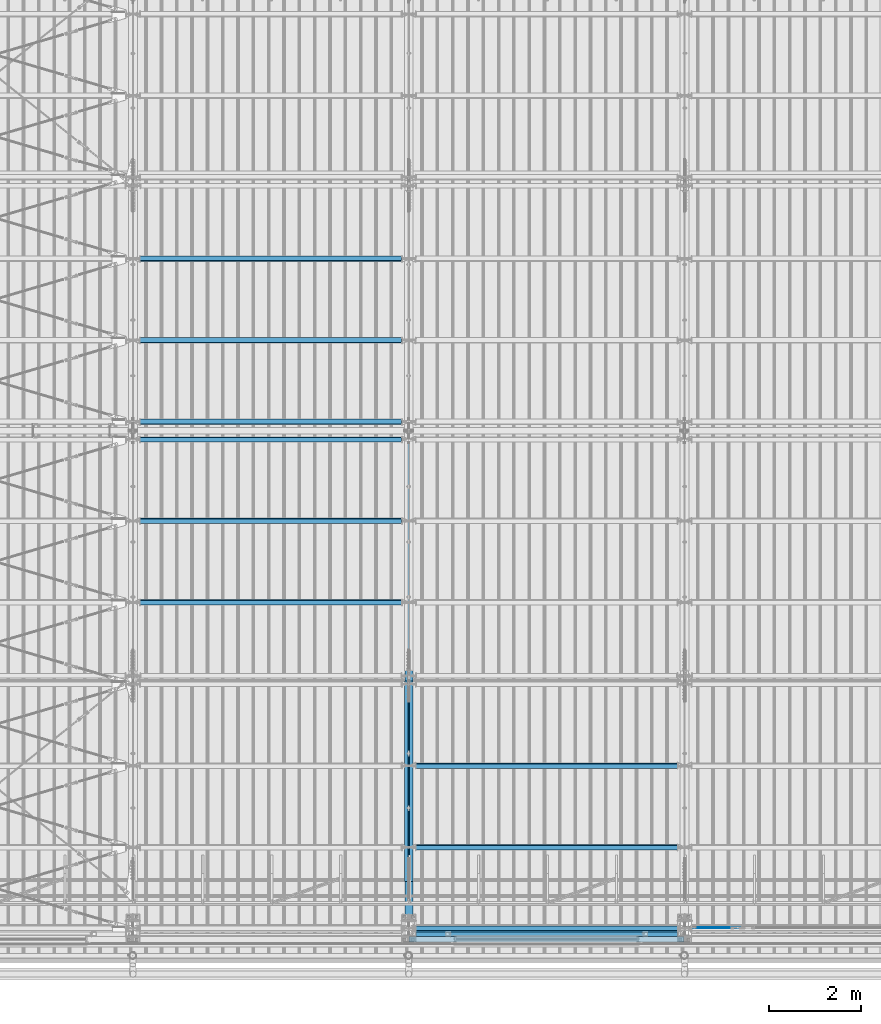
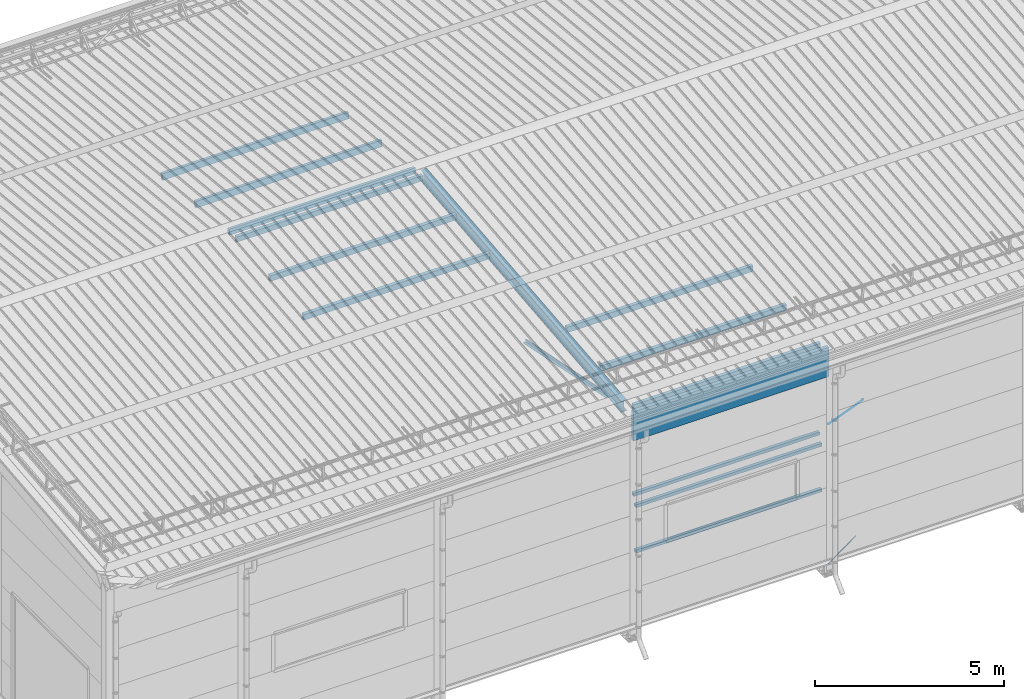
# One storey, part 251 of 709: 16 beams, 2 members, 2 openings, 18 elements without a shape of their own.
"""IFC4 building model written with IfcOpenShell, lengths in millimetres."""

from ifc_helpers import new_model, si_unit, direction, frame, origin_with_axes, place, context, subcontext, project, spatial, line, indexed_curve, outline, extrude, polygons, material, element, aggregate, save


model = new_model("IFC4")

# Units and contexts
model_context = context("Model", 3, precision=0.2, world=origin_with_axes(), true_north=direction((0.0, 1.0)))
body_context = subcontext(model_context, "Body", "Model", "MODEL_VIEW")
reference_context = subcontext(model_context, "Reference", "Model", "MODEL_VIEW")
ifc_project = project(units=[si_unit("LENGTHUNIT", "METRE", prefix="MILLI"), si_unit("AREAUNIT", "SQUARE_METRE"), si_unit("VOLUMEUNIT", "CUBIC_METRE"), si_unit("MASSUNIT", "GRAM", prefix="KILO"), si_unit("TIMEUNIT", "SECOND"), si_unit("PLANEANGLEUNIT", "RADIAN"), si_unit("SOLIDANGLEUNIT", "STERADIAN"), si_unit("THERMODYNAMICTEMPERATUREUNIT", "DEGREE_CELSIUS"), si_unit("LUMINOUSINTENSITYUNIT", "LUMEN")], contexts=[model_context])

# Site, building, storey
site_placement = place(None, origin_with_axes())
site = spatial("IfcSite", under=ifc_project, at=site_placement, CompositionType="ELEMENT")
building_placement = place(site_placement, origin_with_axes())
building = spatial("IfcBuilding", under=site, at=building_placement, Name="Undefined", CompositionType="ELEMENT")
storey_placement = place(building_placement, origin_with_axes())
storey = spatial("IfcBuildingStorey", under=building, at=storey_placement, Name="Undefined", CompositionType="ELEMENT", Elevation=0.0)

# Assembly, beam
assembly_1_placement = place(storey_placement, frame((16000.0, 346.0, 7089.70002), z_axis=(1.0, 0.0, 0.0), x_axis=(0.0, 0.9950371902, 0.099503719)))
assembly_1 = element("IfcElementAssembly", 1, at=assembly_1_placement, inside=storey)
ifc_material_1 = material(Name="C355-5", Category="STEEL")
beam_1_placement = place(assembly_1_placement, origin_with_axes())
beam_1 = element("IfcBeam", 2, at=beam_1_placement, material=ifc_material_1, ObjectType="432", context=body_context, shape_type="Tessellation", body=[
    polygons([(3.80474, -173.0, -87.0), (4.70474, -164.0, -87.0), (10665.6128, -164.0, -87.0), (10664.7128, -173.0, -87.0), (4.70474, -164.0, -3.0), (10665.6128, -164.0, -3.0), (37.50474, 164.0, -3.0), (10698.4128, 164.0, -3.0), (37.50474, 164.0, -87.0), (10698.4128, 164.0, -87.0), (38.40474, 173.0, -87.0), (10699.3128, 173.0, -87.0), (38.40474, 173.0, 87.0), (10699.3128, 173.0, 87.0), (37.50474, 164.0, 87.0), (10698.4128, 164.0, 87.0), (37.50474, 164.0, 3.0), (10698.4128, 164.0, 3.0), (4.70474, -164.0, 3.0), (10665.6128, -164.0, 3.0), (4.70474, -164.0, 87.0), (10665.6128, -164.0, 87.0), (3.80474, -173.0, 87.0), (10664.7128, -173.0, 87.0)], [[[1, 2, 3, 4]], [[2, 5, 6, 3]], [[5, 7, 8, 6]], [[7, 9, 10, 8]], [[9, 11, 12, 10]], [[11, 13, 14, 12]], [[13, 15, 16, 14]], [[15, 17, 18, 16]], [[17, 19, 20, 18]], [[19, 21, 22, 20]], [[21, 23, 24, 22]], [[23, 1, 4, 24]], [[6, 8, 10, 12, 14, 16, 18, 20, 22, 24, 4, 3]], [[23, 21, 19, 17, 15, 13, 11, 9, 7, 5, 2, 1]]], closed=True),
])
aggregate(assembly_1, [beam_1])

assembly_2_placement = place(storey_placement, frame((15949.0, 350.0596, 7109.99804), z_axis=(0.0, 0.1961161349, 0.9805806757), x_axis=(0.0, 0.9805806757, -0.1961161349)))
assembly_2 = element("IfcElementAssembly", 3, at=assembly_2_placement, inside=storey)
ifc_material_2 = material(Name="C345-5", Category="STEEL")
beam_2_placement = place(assembly_2_placement, origin_with_axes())
beam_2 = element("IfcBeam", 4, at=beam_2_placement, material=ifc_material_2, ObjectType="444", context=body_context, shape_type="Tessellation", body=[
    polygons([(868.11437, -45.0, -45.0), (868.11437, 45.0, -45.0), (5317.375, 45.0, -45.0), (5317.375, -45.0, -45.0), (868.11437, 45.0, -39.0), (5317.375, 45.0, -39.0), (868.11437, -39.0, -39.0), (5317.375, -39.0, -39.0), (868.11437, -39.0, 45.0), (5317.375, -39.0, 45.0), (868.11437, -45.0, 45.0), (5317.375, -45.0, 45.0)], [[[1, 2, 3, 4]], [[2, 5, 6, 3]], [[5, 7, 8, 6]], [[7, 9, 10, 8]], [[9, 11, 12, 10]], [[11, 1, 4, 12]], [[6, 8, 10, 12, 4, 3]], [[11, 9, 7, 5, 2, 1]]], closed=True),
])
aggregate(assembly_2, [beam_2])

assembly_3_placement = place(storey_placement, frame((16051.0, 5677.0596, 6044.59804), z_axis=(0.0, 0.1961161349, 0.9805806757), x_axis=(0.0, -0.9805806757, 0.1961161349)))
assembly_3 = element("IfcElementAssembly", 5, at=assembly_3_placement, inside=storey)
beam_3_placement = place(assembly_3_placement, origin_with_axes())
beam_3 = element("IfcBeam", 6, at=beam_3_placement, material=ifc_material_2, ObjectType="444", context=body_context, shape_type="Tessellation", body=[
    polygons([(115.12039, -45.0, -45.0), (115.12039, 45.0, -45.0), (4564.38102, 45.0, -45.0), (4564.38102, -45.0, -45.0), (115.12039, 45.0, -39.0), (4564.38102, 45.0, -39.0), (115.12039, -39.0, -39.0), (4564.38102, -39.0, -39.0), (115.12039, -39.0, 45.0), (4564.38102, -39.0, 45.0), (115.12039, -45.0, 45.0), (4564.38102, -45.0, 45.0)], [[[1, 2, 3, 4]], [[2, 5, 6, 3]], [[5, 7, 8, 6]], [[7, 9, 10, 8]], [[9, 11, 12, 10]], [[11, 1, 4, 12]], [[6, 8, 10, 12, 4, 3]], [[11, 9, 7, 5, 2, 1]]], closed=True),
])
aggregate(assembly_3, [beam_3])

assembly_4_placement = place(storey_placement, frame((16000.0, 50.0, 2550.0), z_axis=(0.0, 0.0, -1.0), x_axis=(1.0, 0.0, 0.0)))
assembly_4 = element("IfcElementAssembly", 7, at=assembly_4_placement, inside=storey)
ifc_material_3 = material(Name="C355", Category="STEEL")
beam_4_placement = place(assembly_4_placement, origin_with_axes())
beam_4 = element("IfcBeam", 8, at=beam_4_placement, material=ifc_material_3, ObjectType="545", context=body_context, shape_type="Tessellation", body=[
    polygons([(155.0, -47.0, -47.0), (155.0, -47.0, 47.0), (5845.0, -47.0, 47.0), (5845.0, -47.0, -47.0), (155.0, 47.0, 47.0), (5845.0, 47.0, 47.0), (155.0, 47.0, -47.0), (5845.0, 47.0, -47.0), (155.0, -50.0, -50.0), (155.0, 50.0, -50.0), (5845.0, 50.0, -50.0), (5845.0, -50.0, -50.0), (155.0, 50.0, 50.0), (5845.0, 50.0, 50.0), (155.0, -50.0, 50.0), (5845.0, -50.0, 50.0)], [[[1, 2, 3, 4]], [[2, 5, 6, 3]], [[5, 7, 8, 6]], [[7, 1, 4, 8]], [[9, 10, 11, 12]], [[10, 13, 14, 11]], [[13, 15, 16, 14]], [[15, 9, 12, 16]], [[14, 16, 12, 11], [6, 8, 4, 3]], [[15, 13, 10, 9], [7, 5, 2, 1]]], closed=True),
])
aggregate(assembly_4, [beam_4])

assembly_5_placement = place(storey_placement, frame((16000.0, 50.0, 4020.0), z_axis=(0.0, 0.0, -1.0), x_axis=(1.0, 0.0, 0.0)))
assembly_5 = element("IfcElementAssembly", 9, at=assembly_5_placement, inside=storey)
beam_5_placement = place(assembly_5_placement, origin_with_axes())
beam_5 = element("IfcBeam", 10, at=beam_5_placement, material=ifc_material_3, ObjectType="545", context=body_context, shape_type="Tessellation", body=[
    polygons([(155.0, -47.0, -47.0), (155.0, -47.0, 47.0), (5845.0, -47.0, 47.0), (5845.0, -47.0, -47.0), (155.0, 47.0, 47.0), (5845.0, 47.0, 47.0), (155.0, 47.0, -47.0), (5845.0, 47.0, -47.0), (155.0, -50.0, -50.0), (155.0, 50.0, -50.0), (5845.0, 50.0, -50.0), (5845.0, -50.0, -50.0), (155.0, 50.0, 50.0), (5845.0, 50.0, 50.0), (155.0, -50.0, 50.0), (5845.0, -50.0, 50.0)], [[[1, 2, 3, 4]], [[2, 5, 6, 3]], [[5, 7, 8, 6]], [[7, 1, 4, 8]], [[9, 10, 11, 12]], [[10, 13, 14, 11]], [[13, 15, 16, 14]], [[15, 9, 12, 16]], [[14, 16, 12, 11], [6, 8, 4, 3]], [[15, 13, 10, 9], [7, 5, 2, 1]]], closed=True),
])
aggregate(assembly_5, [beam_5])

assembly_6_placement = place(storey_placement, frame((16000.0, 173.0, 4310.0), z_axis=(0.0, 0.0, -1.0), x_axis=(1.0, 0.0, 0.0)))
assembly_6 = element("IfcElementAssembly", 11, at=assembly_6_placement, inside=storey)
beam_6_placement = place(assembly_6_placement, origin_with_axes())
beam_6 = element("IfcBeam", 12, at=beam_6_placement, material=ifc_material_3, ObjectType="546", context=body_context, shape_type="Tessellation", body=[
    polygons([(155.0, -47.0, -47.0), (155.0, -47.0, 47.0), (5845.0, -47.0, 47.0), (5845.0, -47.0, -47.0), (155.0, 47.0, 47.0), (5845.0, 47.0, 47.0), (155.0, 47.0, -47.0), (5845.0, 47.0, -47.0), (155.0, -50.0, -50.0), (155.0, 50.0, -50.0), (5845.0, 50.0, -50.0), (5845.0, -50.0, -50.0), (155.0, 50.0, 50.0), (5845.0, 50.0, 50.0), (155.0, -50.0, 50.0), (5845.0, -50.0, 50.0)], [[[1, 2, 3, 4]], [[2, 5, 6, 3]], [[5, 7, 8, 6]], [[7, 1, 4, 8]], [[9, 10, 11, 12]], [[10, 13, 14, 11]], [[13, 15, 16, 14]], [[15, 9, 12, 16]], [[14, 16, 12, 11], [6, 8, 4, 3]], [[15, 13, 10, 9], [7, 5, 2, 1]]], closed=True),
])
aggregate(assembly_6, [beam_6])

# Assembly, member, voiding feature
assembly_7_placement = place(storey_placement, frame((22000.0, 189.0, -155.0), z_axis=(0.0, -1.0, 0.0), x_axis=(0.8064830392, 0.0, 0.5912572262)))
assembly_7 = element("IfcElementAssembly", 13, at=assembly_7_placement, inside=storey)
member_1_placement = place(assembly_7_placement, origin_with_axes())
member_1 = element("IfcMember", 14, at=member_1_placement, material=ifc_material_1, ObjectType="548", context=body_context, shape_type="Tessellation", body=[
    polygons([(1390.0, 7.36122, 4.25), (1390.0, 6.01041, 6.01041), (1390.0, 4.25, 7.36122), (1390.0, 2.19996, 8.21037), (1390.0, 0.0, 8.5), (1390.0, -2.19996, 8.21037), (1390.0, -4.25, 7.36122), (1390.0, -6.01041, 6.01041), (1390.0, -7.36122, 4.25), (1390.0, -8.21037, 2.19996), (1390.0, -8.5, 0.0), (1390.0, -8.21037, -2.19996), (1390.0, -7.36122, -4.25), (1390.0, -6.01041, -6.01041), (1390.0, -4.25, -7.36122), (1390.0, -2.19996, -8.21037), (1390.0, 0.0, -8.5), (1390.0, 2.19996, -8.21037), (1390.0, 4.25, -7.36122), (1390.0, 6.01041, -6.01041), (1390.0, 7.36122, -4.25), (1390.0, 8.21037, -2.19996), (1390.0, 8.5, 0.0), (1390.0, 8.21037, 2.19996), (1210.0, 8.21037, 2.19996), (1210.0, 7.36122, 4.25), (1210.0, 6.01041, 6.01041), (1210.0, 4.25, 7.36122), (1210.0, 2.19996, 8.21037), (1210.0, 0.0, 8.5), (1210.0, -2.19996, 8.21037), (1210.0, -4.25, 7.36122), (1210.0, -6.01041, 6.01041), (1210.0, -7.36122, 4.25), (1210.0, -8.21037, 2.19996), (1210.0, -8.5, 0.0), (1210.0, -8.21037, -2.19996), (1210.0, -7.36122, -4.25), (1210.0, -6.01041, -6.01041), (1210.0, -4.25, -7.36122), (1210.0, -2.19996, -8.21037), (1210.0, 0.0, -8.5), (1210.0, 2.19996, -8.21037), (1210.0, 4.25, -7.36122), (1210.0, 6.01041, -6.01041), (1210.0, 7.36122, -4.25), (1210.0, 8.21037, -2.19996), (1210.0, 8.5, 0.0), (1210.0, 10.0, 0.0), (1210.0, 9.65926, 2.58819), (1210.0, 8.66025, 5.0), (1210.0, 7.07107, 7.07107), (1210.0, 5.0, 8.66025), (1210.0, 2.58819, 9.65926), (1210.0, 0.0, 10.0), (1210.0, -2.58819, 9.65926), (1210.0, -5.0, 8.66025), (1210.0, -7.07107, 7.07107), (1210.0, -8.66025, 5.0), (1210.0, -9.65926, 2.58819), (1210.0, -10.0, 0.0), (1210.0, -9.65926, -2.58819), (1210.0, -8.66025, -5.0), (1210.0, -7.07107, -7.07107), (1210.0, -5.0, -8.66025), (1210.0, -2.58819, -9.65926), (1210.0, 0.0, -10.0), (1210.0, 2.58819, -9.65926), (1210.0, 5.0, -8.66025), (1210.0, 7.07107, -7.07107), (1210.0, 8.66025, -5.0), (1210.0, 9.65926, -2.58819), (174.17845, 2.58819, 9.65926), (174.17845, 5.0, 8.66025), (174.17845, 7.07107, 7.07107), (174.17845, 8.66025, 5.0), (174.17845, 9.65926, 2.58819), (174.17845, 10.0, 0.0), (174.17845, 9.65926, -2.58819), (174.17845, 8.66025, -5.0), (174.17845, 7.07107, -7.07107), (174.17845, 5.0, -8.66025), (174.17845, 2.58819, -9.65926), (174.17845, 0.0, -10.0), (174.17845, -2.58819, -9.65926), (174.17845, -5.0, -8.66025), (174.17845, -7.07107, -7.07107), (174.17845, -8.66025, -5.0), (174.17845, -9.65926, -2.58819), (174.17845, -10.0, 0.0), (174.17845, -9.65926, 2.58819), (174.17845, -8.66025, 5.0), (174.17845, -7.07107, 7.07107), (174.17845, -5.0, 8.66025), (174.17845, -2.58819, 9.65926), (174.17845, 0.0, 10.0)], [[[1, 2, 3, 4, 5, 6, 7, 8, 9, 10, 11, 12, 13, 14, 15, 16, 17, 18, 19, 20, 21, 22, 23, 24]], [[24, 25, 26, 1]], [[1, 26, 27, 2]], [[2, 27, 28, 3]], [[3, 28, 29, 4]], [[4, 29, 30, 5]], [[5, 30, 31, 6]], [[6, 31, 32, 7]], [[7, 32, 33, 8]], [[8, 33, 34, 9]], [[9, 34, 35, 10]], [[10, 35, 36, 11]], [[11, 36, 37, 12]], [[12, 37, 38, 13]], [[13, 38, 39, 14]], [[14, 39, 40, 15]], [[15, 40, 41, 16]], [[16, 41, 42, 17]], [[17, 42, 43, 18]], [[18, 43, 44, 19]], [[19, 44, 45, 20]], [[20, 45, 46, 21]], [[21, 46, 47, 22]], [[22, 47, 48, 23]], [[23, 48, 25, 24]], [[49, 50, 51, 52, 53, 54, 55, 56, 57, 58, 59, 60, 61, 62, 63, 64, 65, 66, 67, 68, 69, 70, 71, 72], [47, 46, 45, 44, 43, 42, 41, 40, 39, 38, 37, 36, 35, 34, 33, 32, 31, 30, 29, 28, 27, 26, 25, 48]], [[73, 74, 75, 76, 77, 78, 79, 80, 81, 82, 83, 84, 85, 86, 87, 88, 89, 90, 91, 92, 93, 94, 95, 96]], [[79, 78, 49, 72]], [[80, 79, 72, 71]], [[81, 80, 71, 70]], [[82, 81, 70, 69]], [[83, 82, 69, 68]], [[84, 83, 68, 67]], [[85, 84, 67, 66]], [[86, 85, 66, 65]], [[87, 86, 65, 64]], [[88, 87, 64, 63]], [[89, 88, 63, 62]], [[90, 89, 62, 61]], [[91, 90, 61, 60]], [[92, 91, 60, 59]], [[93, 92, 59, 58]], [[94, 93, 58, 57]], [[95, 94, 57, 56]], [[96, 95, 56, 55]], [[73, 96, 55, 54]], [[74, 73, 54, 53]], [[75, 74, 53, 52]], [[76, 75, 52, 51]], [[77, 76, 51, 50]], [[78, 77, 50, 49]]], closed=True),
])
voiding_feature_1_placement = place(member_1_placement, frame((1390.0, 0.0, 0.0), z_axis=(0.0, 1.0, 0.0), x_axis=(-1.0, 0.0, 0.0)))
element("IfcVoidingFeature", 15, at=voiding_feature_1_placement, cuts=member_1, PredefinedType="HOLE", context=reference_context, identifier="Reference", shape_type="SolidModel", body=[
    extrude(outline(indexed_curve([(10.5, 0.0), (10.14222, 2.7176), (9.09327, 5.25), (7.42462, 7.42462), (5.25, 9.09327), (2.7176, 10.14222), (0.0, 10.5), (-2.7176, 10.14222), (-5.25, 9.09327), (-7.42462, 7.42462), (-9.09327, 5.25), (-10.14222, 2.7176), (-10.5, 0.0), (-10.14222, -2.7176), (-9.09327, -5.25), (-7.42462, -7.42462), (-5.25, -9.09327), (-2.7176, -10.14222), (0.0, -10.5), (2.7176, -10.14222), (5.25, -9.09327), (7.42462, -7.42462), (9.09327, -5.25), (10.14222, -2.7176)], segments=[line(1, 2, 3, 4, 5, 6, 7, 8, 9, 10, 11, 12, 13, 14, 15, 16, 17, 18, 19, 20, 21, 22, 23, 24, 1)])), frame((0.0, 0.0, 0.0), z_axis=(-1.0, 0.0, 0.0), x_axis=(0.0, 0.0, 1.0)), (0.0, 0.0, -1.0), 180.0),
])
aggregate(assembly_7, [member_1])

assembly_8_placement = place(storey_placement, frame((22087.0, 189.0, 4440.0), z_axis=(0.0, -1.0, 0.0), x_axis=(0.9286065, 0.0, 0.371065989)))
assembly_8 = element("IfcElementAssembly", 16, at=assembly_8_placement, inside=storey)
member_2_placement = place(assembly_8_placement, origin_with_axes())
member_2 = element("IfcMember", 17, at=member_2_placement, material=ifc_material_1, ObjectType="515", context=body_context, shape_type="Tessellation", body=[
    polygons([(1390.0, 7.36122, 4.25), (1390.0, 6.01041, 6.01041), (1390.0, 4.25, 7.36122), (1390.0, 2.19996, 8.21037), (1390.0, 0.0, 8.5), (1390.0, -2.19996, 8.21037), (1390.0, -4.25, 7.36122), (1390.0, -6.01041, 6.01041), (1390.0, -7.36122, 4.25), (1390.0, -8.21037, 2.19996), (1390.0, -8.5, 0.0), (1390.0, -8.21037, -2.19996), (1390.0, -7.36122, -4.25), (1390.0, -6.01041, -6.01041), (1390.0, -4.25, -7.36122), (1390.0, -2.19996, -8.21037), (1390.0, 0.0, -8.5), (1390.0, 2.19996, -8.21037), (1390.0, 4.25, -7.36122), (1390.0, 6.01041, -6.01041), (1390.0, 7.36122, -4.25), (1390.0, 8.21037, -2.19996), (1390.0, 8.5, 0.0), (1390.0, 8.21037, 2.19996), (1210.0, 8.21037, 2.19996), (1210.0, 7.36122, 4.25), (1210.0, 6.01041, 6.01041), (1210.0, 4.25, 7.36122), (1210.0, 2.19996, 8.21037), (1210.0, 0.0, 8.5), (1210.0, -2.19996, 8.21037), (1210.0, -4.25, 7.36122), (1210.0, -6.01041, 6.01041), (1210.0, -7.36122, 4.25), (1210.0, -8.21037, 2.19996), (1210.0, -8.5, 0.0), (1210.0, -8.21037, -2.19996), (1210.0, -7.36122, -4.25), (1210.0, -6.01041, -6.01041), (1210.0, -4.25, -7.36122), (1210.0, -2.19996, -8.21037), (1210.0, 0.0, -8.5), (1210.0, 2.19996, -8.21037), (1210.0, 4.25, -7.36122), (1210.0, 6.01041, -6.01041), (1210.0, 7.36122, -4.25), (1210.0, 8.21037, -2.19996), (1210.0, 8.5, 0.0), (1210.0, 10.0, 0.0), (1210.0, 9.65926, 2.58819), (1210.0, 8.66025, 5.0), (1210.0, 7.07107, 7.07107), (1210.0, 5.0, 8.66025), (1210.0, 2.58819, 9.65926), (1210.0, 0.0, 10.0), (1210.0, -2.58819, 9.65926), (1210.0, -5.0, 8.66025), (1210.0, -7.07107, 7.07107), (1210.0, -8.66025, 5.0), (1210.0, -9.65926, 2.58819), (1210.0, -10.0, 0.0), (1210.0, -9.65926, -2.58819), (1210.0, -8.66025, -5.0), (1210.0, -7.07107, -7.07107), (1210.0, -5.0, -8.66025), (1210.0, -2.58819, -9.65926), (1210.0, 0.0, -10.0), (1210.0, 2.58819, -9.65926), (1210.0, 5.0, -8.66025), (1210.0, 7.07107, -7.07107), (1210.0, 8.66025, -5.0), (1210.0, 9.65926, -2.58819), (70.0, 2.58819, 9.65926), (70.0, 5.0, 8.66025), (70.0, 7.07107, 7.07107), (70.0, 8.66025, 5.0), (70.0, 9.65926, 2.58819), (70.0, 10.0, 0.0), (70.0, 9.65926, -2.58819), (70.0, 8.66025, -5.0), (70.0, 7.07107, -7.07107), (70.0, 5.0, -8.66025), (70.0, 2.58819, -9.65926), (70.0, 0.0, -10.0), (70.0, -2.58819, -9.65926), (70.0, -5.0, -8.66025), (70.0, -7.07107, -7.07107), (70.0, -8.66025, -5.0), (70.0, -9.65926, -2.58819), (70.0, -10.0, 0.0), (70.0, -9.65926, 2.58819), (70.0, -8.66025, 5.0), (70.0, -7.07107, 7.07107), (70.0, -5.0, 8.66025), (70.0, -2.58819, 9.65926), (70.0, 0.0, 10.0)], [[[1, 2, 3, 4, 5, 6, 7, 8, 9, 10, 11, 12, 13, 14, 15, 16, 17, 18, 19, 20, 21, 22, 23, 24]], [[24, 25, 26, 1]], [[1, 26, 27, 2]], [[2, 27, 28, 3]], [[3, 28, 29, 4]], [[4, 29, 30, 5]], [[5, 30, 31, 6]], [[6, 31, 32, 7]], [[7, 32, 33, 8]], [[8, 33, 34, 9]], [[9, 34, 35, 10]], [[10, 35, 36, 11]], [[11, 36, 37, 12]], [[12, 37, 38, 13]], [[13, 38, 39, 14]], [[14, 39, 40, 15]], [[15, 40, 41, 16]], [[16, 41, 42, 17]], [[17, 42, 43, 18]], [[18, 43, 44, 19]], [[19, 44, 45, 20]], [[20, 45, 46, 21]], [[21, 46, 47, 22]], [[22, 47, 48, 23]], [[23, 48, 25, 24]], [[49, 50, 51, 52, 53, 54, 55, 56, 57, 58, 59, 60, 61, 62, 63, 64, 65, 66, 67, 68, 69, 70, 71, 72], [47, 46, 45, 44, 43, 42, 41, 40, 39, 38, 37, 36, 35, 34, 33, 32, 31, 30, 29, 28, 27, 26, 25, 48]], [[73, 74, 75, 76, 77, 78, 79, 80, 81, 82, 83, 84, 85, 86, 87, 88, 89, 90, 91, 92, 93, 94, 95, 96]], [[79, 78, 49, 72]], [[80, 79, 72, 71]], [[81, 80, 71, 70]], [[82, 81, 70, 69]], [[83, 82, 69, 68]], [[84, 83, 68, 67]], [[85, 84, 67, 66]], [[86, 85, 66, 65]], [[87, 86, 65, 64]], [[88, 87, 64, 63]], [[89, 88, 63, 62]], [[90, 89, 62, 61]], [[91, 90, 61, 60]], [[92, 91, 60, 59]], [[93, 92, 59, 58]], [[94, 93, 58, 57]], [[95, 94, 57, 56]], [[96, 95, 56, 55]], [[73, 96, 55, 54]], [[74, 73, 54, 53]], [[75, 74, 53, 52]], [[76, 75, 52, 51]], [[77, 76, 51, 50]], [[78, 77, 50, 49]]], closed=True),
])
voiding_feature_2_placement = place(member_2_placement, frame((1390.0, 0.0, 0.0), z_axis=(0.0, 1.0, 0.0), x_axis=(-1.0, 0.0, 0.0)))
element("IfcVoidingFeature", 18, at=voiding_feature_2_placement, cuts=member_2, PredefinedType="HOLE", context=reference_context, identifier="Reference", shape_type="SolidModel", body=[
    extrude(outline(indexed_curve([(10.5, 0.0), (10.14222, 2.7176), (9.09327, 5.25), (7.42462, 7.42462), (5.25, 9.09327), (2.7176, 10.14222), (0.0, 10.5), (-2.7176, 10.14222), (-5.25, 9.09327), (-7.42462, 7.42462), (-9.09327, 5.25), (-10.14222, 2.7176), (-10.5, 0.0), (-10.14222, -2.7176), (-9.09327, -5.25), (-7.42462, -7.42462), (-5.25, -9.09327), (-2.7176, -10.14222), (0.0, -10.5), (2.7176, -10.14222), (5.25, -9.09327), (7.42462, -7.42462), (9.09327, -5.25), (10.14222, -2.7176)], segments=[line(1, 2, 3, 4, 5, 6, 7, 8, 9, 10, 11, 12, 13, 14, 15, 16, 17, 18, 19, 20, 21, 22, 23, 24, 1)])), frame((0.0, 0.0, 0.0), z_axis=(-1.0, 0.0, 0.0), x_axis=(0.0, 0.0, 1.0)), (0.0, 0.0, -1.0), 180.0),
])
aggregate(assembly_8, [member_2])

# Assembly, beam
assembly_9_placement = place(storey_placement, frame((10000.0, 7263.34988, 7854.7991), z_axis=(0.0, 0.9950371902, 0.099503719), x_axis=(1.0, 0.0, 0.0)))
assembly_9 = element("IfcElementAssembly", 19, at=assembly_9_placement, inside=storey)
beam_7_placement = place(assembly_9_placement, origin_with_axes())
beam_7 = element("IfcBeam", 20, at=beam_7_placement, material=ifc_material_3, ObjectType="579", context=body_context, shape_type="Tessellation", body=[
    polygons([(155.0, -96.0, -46.0), (155.0, -96.0, 46.0), (5845.0, -96.0, 46.0), (5845.0, -96.0, -46.0), (155.0, 96.0, 46.0), (5845.0, 96.0, 46.0), (155.0, 96.0, -46.0), (5845.0, 96.0, -46.0), (155.0, -100.0, -50.0), (155.0, 100.0, -50.0), (5845.0, 100.0, -50.0), (5845.0, -100.0, -50.0), (155.0, 100.0, 50.0), (5845.0, 100.0, 50.0), (155.0, -100.0, 50.0), (5845.0, -100.0, 50.0)], [[[1, 2, 3, 4]], [[2, 5, 6, 3]], [[5, 7, 8, 6]], [[7, 1, 4, 8]], [[9, 10, 11, 12]], [[10, 13, 14, 11]], [[13, 15, 16, 14]], [[15, 9, 12, 16]], [[14, 16, 12, 11], [6, 8, 4, 3]], [[15, 13, 10, 9], [7, 5, 2, 1]]], closed=True),
])
aggregate(assembly_9, [beam_7])

assembly_10_placement = place(storey_placement, frame((10000.0, 9036.65012, 8032.12913), z_axis=(0.0, 0.9950371902, 0.099503719), x_axis=(1.0, 0.0, 0.0)))
assembly_10 = element("IfcElementAssembly", 21, at=assembly_10_placement, inside=storey)
beam_8_placement = place(assembly_10_placement, origin_with_axes())
beam_8 = element("IfcBeam", 22, at=beam_8_placement, material=ifc_material_3, ObjectType="579", context=body_context, shape_type="Tessellation", body=[
    polygons([(155.0, -96.0, -46.0), (155.0, -96.0, 46.0), (5845.0, -96.0, 46.0), (5845.0, -96.0, -46.0), (155.0, 96.0, 46.0), (5845.0, 96.0, 46.0), (155.0, 96.0, -46.0), (5845.0, 96.0, -46.0), (155.0, -100.0, -50.0), (155.0, 100.0, -50.0), (5845.0, 100.0, -50.0), (5845.0, -100.0, -50.0), (155.0, 100.0, 50.0), (5845.0, 100.0, 50.0), (155.0, -100.0, 50.0), (5845.0, -100.0, 50.0)], [[[1, 2, 3, 4]], [[2, 5, 6, 3]], [[5, 7, 8, 6]], [[7, 1, 4, 8]], [[9, 10, 11, 12]], [[10, 13, 14, 11]], [[13, 15, 16, 14]], [[15, 9, 12, 16]], [[14, 16, 12, 11], [6, 8, 4, 3]], [[15, 13, 10, 9], [7, 5, 2, 1]]], closed=True),
])
aggregate(assembly_10, [beam_8])

assembly_11_placement = place(storey_placement, frame((10000.0, 10808.95533, 8219.40952), z_axis=(0.0, 0.9950371902, 0.099503719), x_axis=(1.0, 0.0, 0.0)))
assembly_11 = element("IfcElementAssembly", 23, at=assembly_11_placement, inside=storey)
beam_9_placement = place(assembly_11_placement, origin_with_axes())
beam_9 = element("IfcBeam", 24, at=beam_9_placement, material=ifc_material_3, ObjectType="580", context=body_context, shape_type="Tessellation", body=[
    polygons([(155.0, -86.0, -46.0), (155.0, -86.0, 46.0), (5845.0, -86.0, 46.0), (5845.0, -86.0, -46.0), (155.0, 86.0, 46.0), (5845.0, 86.0, 46.0), (155.0, 86.0, -46.0), (5845.0, 86.0, -46.0), (155.0, -90.0, -50.0), (155.0, 90.0, -50.0), (5845.0, 90.0, -50.0), (5845.0, -90.0, -50.0), (155.0, 90.0, 50.0), (5845.0, 90.0, 50.0), (155.0, -90.0, 50.0), (5845.0, -90.0, 50.0)], [[[1, 2, 3, 4]], [[2, 5, 6, 3]], [[5, 7, 8, 6]], [[7, 1, 4, 8]], [[9, 10, 11, 12]], [[10, 13, 14, 11]], [[13, 15, 16, 14]], [[15, 9, 12, 16]], [[14, 16, 12, 11], [6, 8, 4, 3]], [[15, 13, 10, 9], [7, 5, 2, 1]]], closed=True),
])
aggregate(assembly_11, [beam_9])

assembly_12_placement = place(storey_placement, frame((16000.0, 11191.04467, 8219.40952), z_axis=(0.0, -0.9950371902, 0.099503719), x_axis=(-1.0, 0.0, 0.0)))
assembly_12 = element("IfcElementAssembly", 25, at=assembly_12_placement, inside=storey)
beam_10_placement = place(assembly_12_placement, origin_with_axes())
beam_10 = element("IfcBeam", 26, at=beam_10_placement, material=ifc_material_3, ObjectType="580", context=body_context, shape_type="Tessellation", body=[
    polygons([(155.0, -86.0, -46.0), (155.0, -86.0, 46.0), (5845.0, -86.0, 46.0), (5845.0, -86.0, -46.0), (155.0, 86.0, 46.0), (5845.0, 86.0, 46.0), (155.0, 86.0, -46.0), (5845.0, 86.0, -46.0), (155.0, -90.0, -50.0), (155.0, 90.0, -50.0), (5845.0, 90.0, -50.0), (5845.0, -90.0, -50.0), (155.0, 90.0, 50.0), (5845.0, 90.0, 50.0), (155.0, -90.0, 50.0), (5845.0, -90.0, 50.0)], [[[1, 2, 3, 4]], [[2, 5, 6, 3]], [[5, 7, 8, 6]], [[7, 1, 4, 8]], [[9, 10, 11, 12]], [[10, 13, 14, 11]], [[13, 15, 16, 14]], [[15, 9, 12, 16]], [[14, 16, 12, 11], [6, 8, 4, 3]], [[15, 13, 10, 9], [7, 5, 2, 1]]], closed=True),
])
aggregate(assembly_12, [beam_10])

assembly_13_placement = place(storey_placement, frame((16000.0, 12963.34988, 8032.12913), z_axis=(0.0, -0.9950371902, 0.099503719), x_axis=(-1.0, 0.0, 0.0)))
assembly_13 = element("IfcElementAssembly", 27, at=assembly_13_placement, inside=storey)
beam_11_placement = place(assembly_13_placement, origin_with_axes())
beam_11 = element("IfcBeam", 28, at=beam_11_placement, material=ifc_material_3, ObjectType="579", context=body_context, shape_type="Tessellation", body=[
    polygons([(155.0, -96.0, -46.0), (155.0, -96.0, 46.0), (5845.0, -96.0, 46.0), (5845.0, -96.0, -46.0), (155.0, 96.0, 46.0), (5845.0, 96.0, 46.0), (155.0, 96.0, -46.0), (5845.0, 96.0, -46.0), (155.0, -100.0, -50.0), (155.0, 100.0, -50.0), (5845.0, 100.0, -50.0), (5845.0, -100.0, -50.0), (155.0, 100.0, 50.0), (5845.0, 100.0, 50.0), (155.0, -100.0, 50.0), (5845.0, -100.0, 50.0)], [[[1, 2, 3, 4]], [[2, 5, 6, 3]], [[5, 7, 8, 6]], [[7, 1, 4, 8]], [[9, 10, 11, 12]], [[10, 13, 14, 11]], [[13, 15, 16, 14]], [[15, 9, 12, 16]], [[14, 16, 12, 11], [6, 8, 4, 3]], [[15, 13, 10, 9], [7, 5, 2, 1]]], closed=True),
])
aggregate(assembly_13, [beam_11])

assembly_14_placement = place(storey_placement, frame((16000.0, 14736.65012, 7854.7991), z_axis=(0.0, -0.9950371902, 0.099503719), x_axis=(-1.0, 0.0, 0.0)))
assembly_14 = element("IfcElementAssembly", 29, at=assembly_14_placement, inside=storey)
beam_12_placement = place(assembly_14_placement, origin_with_axes())
beam_12 = element("IfcBeam", 30, at=beam_12_placement, material=ifc_material_3, ObjectType="579", context=body_context, shape_type="Tessellation", body=[
    polygons([(155.0, -96.0, -46.0), (155.0, -96.0, 46.0), (5845.0, -96.0, 46.0), (5845.0, -96.0, -46.0), (155.0, 96.0, 46.0), (5845.0, 96.0, 46.0), (155.0, 96.0, -46.0), (5845.0, 96.0, -46.0), (155.0, -100.0, -50.0), (155.0, 100.0, -50.0), (5845.0, 100.0, -50.0), (5845.0, -100.0, -50.0), (155.0, 100.0, 50.0), (5845.0, 100.0, 50.0), (155.0, -100.0, 50.0), (5845.0, -100.0, 50.0)], [[[1, 2, 3, 4]], [[2, 5, 6, 3]], [[5, 7, 8, 6]], [[7, 1, 4, 8]], [[9, 10, 11, 12]], [[10, 13, 14, 11]], [[13, 15, 16, 14]], [[15, 9, 12, 16]], [[14, 16, 12, 11], [6, 8, 4, 3]], [[15, 13, 10, 9], [7, 5, 2, 1]]], closed=True),
])
aggregate(assembly_14, [beam_12])

assembly_15_placement = place(storey_placement, frame((16000.0, 158.95533, 7154.40952), z_axis=(0.0, 0.9950371902, 0.099503719), x_axis=(1.0, 0.0, 0.0)))
assembly_15 = element("IfcElementAssembly", 31, at=assembly_15_placement, inside=storey)
beam_13_placement = place(assembly_15_placement, origin_with_axes())
beam_13 = element("IfcBeam", 32, at=beam_13_placement, material=ifc_material_3, ObjectType="578", context=body_context, shape_type="Tessellation", body=[
    polygons([(145.0, -86.0, -46.0), (145.0, -86.0, 46.0), (5855.0, -86.0, 46.0), (5855.0, -86.0, -46.0), (145.0, 86.0, 46.0), (5855.0, 86.0, 46.0), (145.0, 86.0, -46.0), (5855.0, 86.0, -46.0), (145.0, -90.0, -50.0), (145.0, 90.0, -50.0), (5855.0, 90.0, -50.0), (5855.0, -90.0, -50.0), (145.0, 90.0, 50.0), (5855.0, 90.0, 50.0), (145.0, -90.0, 50.0), (5855.0, -90.0, 50.0)], [[[1, 2, 3, 4]], [[2, 5, 6, 3]], [[5, 7, 8, 6]], [[7, 1, 4, 8]], [[9, 10, 11, 12]], [[10, 13, 14, 11]], [[13, 15, 16, 14]], [[15, 9, 12, 16]], [[14, 16, 12, 11], [6, 8, 4, 3]], [[15, 13, 10, 9], [7, 5, 2, 1]]], closed=True),
])
aggregate(assembly_15, [beam_13])

assembly_16_placement = place(storey_placement, frame((16000.0, 1936.65012, 7322.12913), z_axis=(0.0, 0.9950371902, 0.099503719), x_axis=(1.0, 0.0, 0.0)))
assembly_16 = element("IfcElementAssembly", 33, at=assembly_16_placement, inside=storey)
beam_14_placement = place(assembly_16_placement, origin_with_axes())
beam_14 = element("IfcBeam", 34, at=beam_14_placement, material=ifc_material_3, ObjectType="579", context=body_context, shape_type="Tessellation", body=[
    polygons([(155.0, -96.0, -46.0), (155.0, -96.0, 46.0), (5845.0, -96.0, 46.0), (5845.0, -96.0, -46.0), (155.0, 96.0, 46.0), (5845.0, 96.0, 46.0), (155.0, 96.0, -46.0), (5845.0, 96.0, -46.0), (155.0, -100.0, -50.0), (155.0, 100.0, -50.0), (5845.0, 100.0, -50.0), (5845.0, -100.0, -50.0), (155.0, 100.0, 50.0), (5845.0, 100.0, 50.0), (155.0, -100.0, 50.0), (5845.0, -100.0, 50.0)], [[[1, 2, 3, 4]], [[2, 5, 6, 3]], [[5, 7, 8, 6]], [[7, 1, 4, 8]], [[9, 10, 11, 12]], [[10, 13, 14, 11]], [[13, 15, 16, 14]], [[15, 9, 12, 16]], [[14, 16, 12, 11], [6, 8, 4, 3]], [[15, 13, 10, 9], [7, 5, 2, 1]]], closed=True),
])
aggregate(assembly_16, [beam_14])

assembly_17_placement = place(storey_placement, frame((16000.0, 3713.34988, 7499.7991), z_axis=(0.0, 0.9950371902, 0.099503719), x_axis=(1.0, 0.0, 0.0)))
assembly_17 = element("IfcElementAssembly", 35, at=assembly_17_placement, inside=storey)
beam_15_placement = place(assembly_17_placement, origin_with_axes())
beam_15 = element("IfcBeam", 36, at=beam_15_placement, material=ifc_material_3, ObjectType="579", context=body_context, shape_type="Tessellation", body=[
    polygons([(155.0, -96.0, -46.0), (155.0, -96.0, 46.0), (5845.0, -96.0, 46.0), (5845.0, -96.0, -46.0), (155.0, 96.0, 46.0), (5845.0, 96.0, 46.0), (155.0, 96.0, -46.0), (5845.0, 96.0, -46.0), (155.0, -100.0, -50.0), (155.0, 100.0, -50.0), (5845.0, 100.0, -50.0), (5845.0, -100.0, -50.0), (155.0, 100.0, 50.0), (5845.0, 100.0, 50.0), (155.0, -100.0, 50.0), (5845.0, -100.0, 50.0)], [[[1, 2, 3, 4]], [[2, 5, 6, 3]], [[5, 7, 8, 6]], [[7, 1, 4, 8]], [[9, 10, 11, 12]], [[10, 13, 14, 11]], [[13, 15, 16, 14]], [[15, 9, 12, 16]], [[14, 16, 12, 11], [6, 8, 4, 3]], [[15, 13, 10, 9], [7, 5, 2, 1]]], closed=True),
])
aggregate(assembly_17, [beam_15])

assembly_18_placement = place(storey_placement, frame((16010.0, -60.0, 6845.0), z_axis=(0.0, 0.0, -1.0), x_axis=(1.0, 0.0, 0.0)))
assembly_18 = element("IfcElementAssembly", 37, at=assembly_18_placement, inside=storey)
ifc_material_4 = material(Name="Insulation", Category="Insulation")
beam_16_placement = place(assembly_18_placement, origin_with_axes())
beam_16 = element("IfcBeam", 38, at=beam_16_placement, material=ifc_material_4, ObjectType="P-108", context=body_context, shape_type="Tessellation", body=[
    polygons([(0.0, 60.0, 595.0), (0.0, -60.0, 595.0), (5980.0, -60.0, 595.0), (5980.0, 60.0, 595.0), (5980.0, 60.0, -351.923), (0.0, 60.0, -351.923), (0.0, -60.0, -351.923), (5980.0, -60.0, -351.923)], [[[1, 2, 3, 4]], [[1, 4, 5, 6]], [[2, 1, 6, 7]], [[3, 2, 7, 8]], [[4, 3, 8, 5]], [[7, 6, 5, 8]]], closed=True),
])
aggregate(assembly_18, [beam_16])

save(model, "model.ifc")
